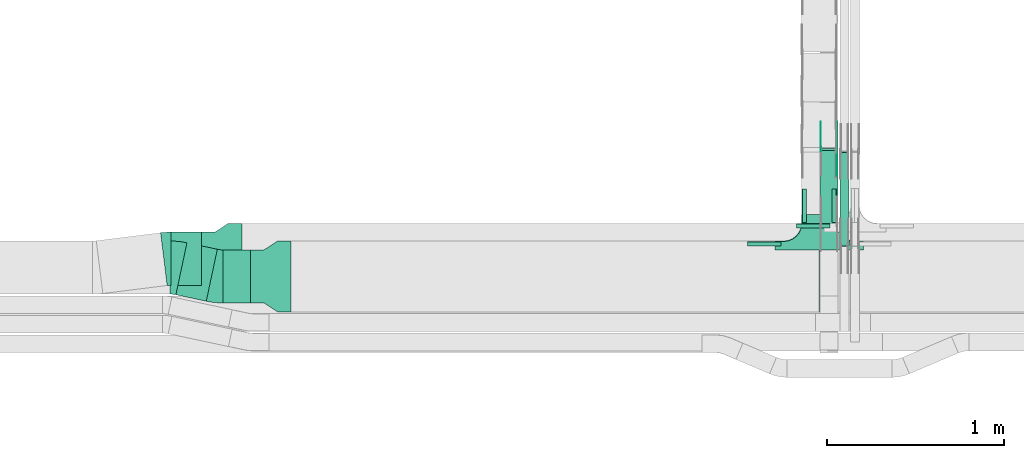
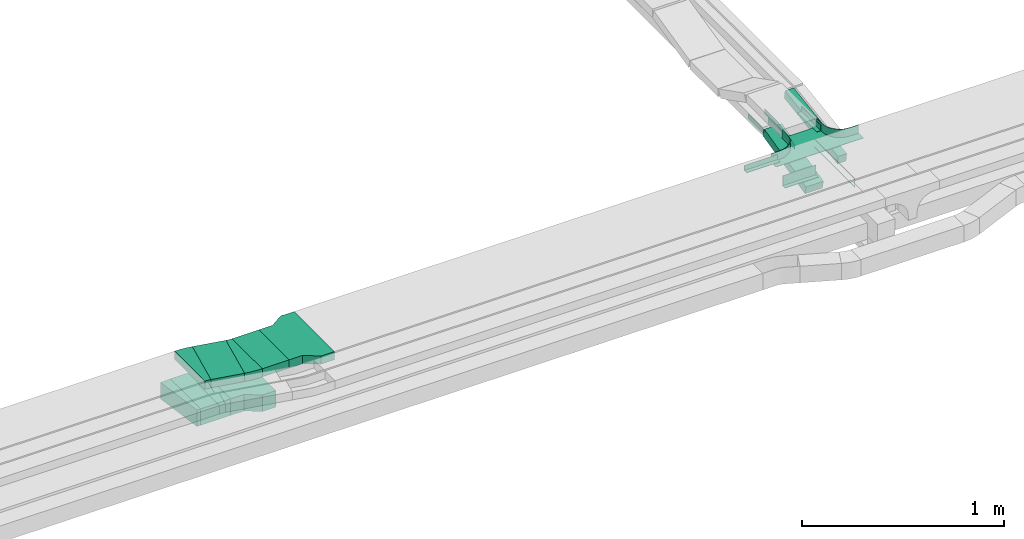
# One storey, part 17 of 28: 13 flow fittings, 5 flow segments.
"""IFC2X3 building model written with IfcOpenShell, lengths in millimetres."""

from ifc_helpers import new_model, entity, si_unit, converted_unit, derived_unit, direction, frame, frame_2d, origin, origin_2d_with_axis, place, context, subcontext, project, spatial, polyline, circle_curve, parameter, trimmed, segment, composite_curve, rectangle, outline, extrude, faceted_brep, source, transform, mapped, material, type_object, type_shapes, element, save


model = new_model("IFC2X3")

# Units and contexts
model_context = context("Model", 3, precision=0.01, world=origin(), true_north=direction((6.12303176911189e-17, 1.0)))
body_context = subcontext(model_context, "Body", "Model", "MODEL_VIEW")
ifc_project = project(units=[si_unit("LENGTHUNIT", "METRE", prefix="MILLI"), si_unit("AREAUNIT", "SQUARE_METRE"), si_unit("VOLUMEUNIT", "CUBIC_METRE"), converted_unit("PLANEANGLEUNIT", "DEGREE", entity("IfcRatioMeasure", 0.0174532925199433), si_unit("PLANEANGLEUNIT", "RADIAN"), dimensions=[0, 0, 0, 0, 0, 0, 0]), si_unit("MASSUNIT", "GRAM", prefix="KILO"), derived_unit("MASSDENSITYUNIT", [(si_unit("MASSUNIT", "GRAM", prefix="KILO"), 1), (si_unit("LENGTHUNIT", "METRE"), -3)]), derived_unit("MOMENTOFINERTIAUNIT", [(si_unit("LENGTHUNIT", "METRE"), 4)]), si_unit("TIMEUNIT", "SECOND"), si_unit("FREQUENCYUNIT", "HERTZ"), si_unit("THERMODYNAMICTEMPERATUREUNIT", "DEGREE_CELSIUS"), derived_unit("THERMALTRANSMITTANCEUNIT", [(si_unit("MASSUNIT", "GRAM", prefix="KILO"), 1), (si_unit("THERMODYNAMICTEMPERATUREUNIT", "KELVIN"), -1), (si_unit("TIMEUNIT", "SECOND"), -3)]), derived_unit("VOLUMETRICFLOWRATEUNIT", [(si_unit("LENGTHUNIT", "METRE"), 3), (si_unit("TIMEUNIT", "SECOND"), -1)]), derived_unit("MASSFLOWRATEUNIT", [(si_unit("MASSUNIT", "GRAM", prefix="KILO"), 1), (si_unit("TIMEUNIT", "SECOND"), -1)]), derived_unit("ROTATIONALFREQUENCYUNIT", [(si_unit("TIMEUNIT", "SECOND"), -1)]), si_unit("ELECTRICCURRENTUNIT", "AMPERE"), si_unit("ELECTRICVOLTAGEUNIT", "VOLT"), si_unit("POWERUNIT", "WATT"), si_unit("FORCEUNIT", "NEWTON", prefix="KILO"), si_unit("ILLUMINANCEUNIT", "LUX"), si_unit("LUMINOUSFLUXUNIT", "LUMEN"), si_unit("LUMINOUSINTENSITYUNIT", "CANDELA"), derived_unit("USERDEFINED", [(si_unit("MASSUNIT", "GRAM", prefix="KILO"), -1), (si_unit("LENGTHUNIT", "METRE"), -2), (si_unit("TIMEUNIT", "SECOND"), 3), (si_unit("LUMINOUSFLUXUNIT", "LUMEN"), 1)]), derived_unit("LINEARVELOCITYUNIT", [(si_unit("LENGTHUNIT", "METRE"), 1), (si_unit("TIMEUNIT", "SECOND"), -1)]), si_unit("PRESSUREUNIT", "PASCAL"), derived_unit("USERDEFINED", [(si_unit("LENGTHUNIT", "METRE"), -2), (si_unit("MASSUNIT", "GRAM", prefix="KILO"), 1), (si_unit("TIMEUNIT", "SECOND"), -2)]), derived_unit("LINEARFORCEUNIT", [(si_unit("MASSUNIT", "GRAM", prefix="KILO"), 1), (si_unit("LENGTHUNIT", "METRE"), 1), (si_unit("TIMEUNIT", "SECOND"), -2), (si_unit("LENGTHUNIT", "METRE"), -1)]), derived_unit("PLANARFORCEUNIT", [(si_unit("MASSUNIT", "GRAM", prefix="KILO"), 1), (si_unit("LENGTHUNIT", "METRE"), 1), (si_unit("TIMEUNIT", "SECOND"), -2), (si_unit("LENGTHUNIT", "METRE"), -2)])], contexts=[model_context])

# Site, building, storey
site_placement = place(None, frame((0.0, -0.00077364408347762, 0.0)))
site = spatial("IfcSite", under=ifc_project, at=site_placement, CompositionType="ELEMENT")
building_placement = place(site_placement, origin())
building = spatial("IfcBuilding", under=site, at=building_placement, CompositionType="ELEMENT")
storey_placement = place(building_placement, origin())
storey = spatial("IfcBuildingStorey", under=building, at=storey_placement, CompositionType="ELEMENT", Elevation=0.0)

# Flow segments
cable_carrier_segment_type = type_object("IfcCableCarrierSegmentType", PredefinedType="CABLETRAYSEGMENT")
flow_segment_1_placement = place(storey_placement, frame((43477.345822446, 8570.00006103515, 2850.0)))
element("IfcFlowSegment", 1, at=flow_segment_1_placement, inside=storey, type_object=cable_carrier_segment_type, context=body_context, shape_type="SweptSolid", body=[
    extrude(rectangle(XDim=153.839138178527, YDim=300.000000000001, at=origin_2d_with_axis()), frame((76.9195690892635, 150.0, 0.0), z_axis=(0.0, 0.0, 1.0), x_axis=(-1.0, 0.0, 0.0)), (0.0, 0.0, 1.0), 50.0000000000005),
])
flow_segment_2_placement = place(storey_placement, frame((46847.7697248974, 9014.64318097615, 2501.67316406554)))
element("IfcFlowSegment", 2, at=flow_segment_2_placement, inside=storey, type_object=cable_carrier_segment_type, context=body_context, shape_type="SweptSolid", body=[
    extrude(rectangle(XDim=50.0000000000002, YDim=426.657179477889, at=frame_2d((-5.11590769747272e-13, 1.22568621918617e-13), x_axis=(0.0, 1.0))), frame((0.0, 213.367766229282, 73.3268359354862), z_axis=(1.0, 0.0, 0.0), x_axis=(0.0, -0.973268623518936, -0.229669733472992)), (0.0, 0.0, 1.0), 99.9999999999945),
])
flow_segment_3_placement = place(storey_placement, frame((46959.820904201, 8891.69675428244, 2720.74533721461)))
element("IfcFlowSegment", 3, at=flow_segment_3_placement, inside=storey, type_object=cable_carrier_segment_type, context=body_context, shape_type="SweptSolid", body=[
    extrude(rectangle(XDim=49.9999999999999, YDim=533.151523501312, at=frame_2d((-5.11590769747272e-13, 7.99360577730113e-14), x_axis=(0.0, 1.0))), frame((0.0, 267.335697614626, 64.2546627854034), z_axis=(1.0, 0.0, 0.0), x_axis=(0.0, 0.988943608506524, 0.148292073942251)), (0.0, 0.0, 1.0), 50.000000000006),
])
flow_segment_4_placement = place(storey_placement, frame((43210.2166770361, 8580.04155239575, 2850.0)))
element("IfcFlowSegment", 4, at=flow_segment_4_placement, inside=storey, type_object=cable_carrier_segment_type, context=body_context, shape_type="SweptSolid", body=[
    extrude(rectangle(XDim=175.424176077719, YDim=299.999999999999, at=frame_2d((4.12114786740858e-12, 1.4352963262354e-12), x_axis=(1.0, 0.0))), frame((116.982122093219, 164.958508639385, 0.0), z_axis=(0.0, 0.0, 1.0), x_axis=(-0.978147600733807, 0.207911690817753, 0.0)), (0.0, 0.0, 1.0), 50.0000000000005),
])
flow_segment_5_placement = place(storey_placement, frame((43181.4742134724, 8670.17178445353, 2600.0)))
element("IfcFlowSegment", 5, at=flow_segment_5_placement, inside=storey, type_object=cable_carrier_segment_type, context=body_context, shape_type="SweptSolid", body=[
    extrude(rectangle(XDim=172.346690728659, YDim=300.000000000001, at=frame_2d((0.0, 5.40012479177676e-13), x_axis=(1.0, 0.0))), frame((86.1733453643297, 150.0, 0.0), z_axis=(0.0, 0.0, 1.0), x_axis=(-1.0, 0.0, 0.0)), (0.0, 0.0, 1.0), 100.000000000001),
])

# Flow fittings
ifc_material_1 = material(Name="G")
cable_carrier_fitting_type_1 = type_object("IfcCableCarrierFittingType", PredefinedType="NOTDEFINED", material=ifc_material_1)
shared_shape_1 = source(origin(), body_context, "Body", "SweptSolid", [
    extrude(outline(composite_curve([segment(trimmed(circle_curve(frame_2d((-44.5901162790698, 0.0), x_axis=(1.0, 0.0)), 12.5), [parameter(90.0000000000007)], [parameter(270.0)], True, "PARAMETER"), True, "CONTINUOUS"), segment(polyline([(-44.5901162790697, -12.5), (-33.0901162790698, -12.5)]), True, "CONTINUOUS"), segment(polyline([(-33.0901162790698, -12.5), (-31.2296511627907, -14.5)]), True, "CONTINUOUS"), segment(polyline([(-31.2296511627907, -14.5), (108.90988372093, -14.5)]), True, "CONTINUOUS"), segment(polyline([(108.90988372093, -14.5), (108.90988372093, 14.5)]), True, "CONTINUOUS"), segment(polyline([(108.90988372093, 14.5), (-31.2296511627907, 14.5)]), True, "CONTINUOUS"), segment(polyline([(-31.2296511627907, 14.5), (-33.0901162790698, 12.5)]), True, "CONTINUOUS"), segment(polyline([(-33.0901162790698, 12.5), (-44.5901162790699, 12.5)]), True, "CONTINUOUS")], self_intersect=False)), frame((44.5901162790698, 0.0, 0.0), z_axis=(0.0, 0.0, -1.0), x_axis=(1.0, 0.0, 0.0)), (0.0, 0.0, -1.0), 2.0),
])
type_shapes(cable_carrier_fitting_type_1, [shared_shape_1])
flow_fitting_1_placement = place(storey_placement, frame((46852.3097248873, 9439.89533631953, 2625.0), z_axis=(-1.0, 0.0, 0.0), x_axis=(0.0, 1.0, 0.0)))
element("IfcFlowFitting", 6, at=flow_fitting_1_placement, inside=storey, type_object=cable_carrier_fitting_type_1, material=ifc_material_1, context=body_context, shape_type="MappedRepresentation", body=[
    mapped(shared_shape_1, transform((0.0, 0.0, 0.0), scale=1.0)),
])
cable_carrier_fitting_type_2 = type_object("IfcCableCarrierFittingType", PredefinedType="NOTDEFINED", material=ifc_material_1)
shared_shape_2 = source(origin(), body_context, "Body", "SweptSolid", [
    extrude(outline(composite_curve([segment(trimmed(circle_curve(frame_2d((-44.5901162790697, 0.0), x_axis=(1.0, 0.0)), 12.5), [parameter(90.0000000000007)], [parameter(270.0)], True, "PARAMETER"), True, "CONTINUOUS"), segment(polyline([(-44.5901162790697, -12.5), (-33.0901162790697, -12.5)]), True, "CONTINUOUS"), segment(polyline([(-33.0901162790697, -12.5), (-31.2296511627907, -14.5)]), True, "CONTINUOUS"), segment(polyline([(-31.2296511627907, -14.5), (108.90988372093, -14.5)]), True, "CONTINUOUS"), segment(polyline([(108.90988372093, -14.5), (108.90988372093, 14.5)]), True, "CONTINUOUS"), segment(polyline([(108.90988372093, 14.5), (-31.2296511627907, 14.5)]), True, "CONTINUOUS"), segment(polyline([(-31.2296511627907, 14.5), (-33.0901162790698, 12.5)]), True, "CONTINUOUS"), segment(polyline([(-33.0901162790698, 12.5), (-44.5901162790699, 12.5)]), True, "CONTINUOUS")], self_intersect=False)), frame((44.5901162790697, 0.0, 0.0)), (0.0, 0.0, 1.0), 2.0),
])
type_shapes(cable_carrier_fitting_type_2, [shared_shape_2])
flow_fitting_2_placement = place(storey_placement, frame((46943.2297249076, 9439.89533631953, 2625.0), z_axis=(1.0, 0.0, 0.0), x_axis=(0.0, 1.0, 0.0)))
element("IfcFlowFitting", 7, at=flow_fitting_2_placement, inside=storey, type_object=cable_carrier_fitting_type_2, material=ifc_material_1, context=body_context, shape_type="MappedRepresentation", body=[
    mapped(shared_shape_2, transform((0.0, 0.0, 0.0), scale=1.0)),
])
cable_carrier_fitting_type_3 = type_object("IfcCableCarrierFittingType", PredefinedType="NOTDEFINED", material=ifc_material_1)
shared_shape_3 = source(origin(), body_context, "Body", "SweptSolid", [
    extrude(outline(composite_curve([segment(trimmed(circle_curve(frame_2d((-44.5901162790698, 0.0), x_axis=(1.0, 0.0)), 12.5), [parameter(90.0000000000007)], [parameter(270.0)], True, "PARAMETER"), True, "CONTINUOUS"), segment(polyline([(-44.5901162790697, -12.5), (-33.0901162790698, -12.5)]), True, "CONTINUOUS"), segment(polyline([(-33.0901162790698, -12.5), (-31.2296511627907, -14.5)]), True, "CONTINUOUS"), segment(polyline([(-31.2296511627907, -14.5), (108.90988372093, -14.5)]), True, "CONTINUOUS"), segment(polyline([(108.90988372093, -14.5), (108.90988372093, 14.5)]), True, "CONTINUOUS"), segment(polyline([(108.90988372093, 14.5), (-31.2296511627907, 14.5)]), True, "CONTINUOUS"), segment(polyline([(-31.2296511627907, 14.5), (-33.0901162790698, 12.5)]), True, "CONTINUOUS"), segment(polyline([(-33.0901162790698, 12.5), (-44.5901162790699, 12.5)]), True, "CONTINUOUS")], self_intersect=False)), frame((44.5901162790698, 0.0, 0.0), z_axis=(0.0, 0.0, -1.0), x_axis=(1.0, 0.0, 0.0)), (0.0, 0.0, -1.0), 2.0),
])
type_shapes(cable_carrier_fitting_type_3, [shared_shape_3])
flow_fitting_3_placement = place(storey_placement, frame((46941.2297249076, 9439.89533631955, 2625.0), z_axis=(1.0, 0.0, 0.0), x_axis=(0.0, -0.973268623517807, -0.229669733477778)))
element("IfcFlowFitting", 8, at=flow_fitting_3_placement, inside=storey, type_object=cable_carrier_fitting_type_3, material=ifc_material_1, context=body_context, shape_type="MappedRepresentation", body=[
    mapped(shared_shape_3, transform((0.0, 0.0, 0.0), scale=1.0)),
])
ifc_material_2 = material()
cable_carrier_fitting_type_4 = type_object("IfcCableCarrierFittingType", PredefinedType="NOTDEFINED", material=ifc_material_2)
shared_shape_4 = source(origin(), body_context, "Body", "SweptSolid", [
    extrude(outline(polyline([(-21.5000000000001, -9.16666666666668), (40.5, -9.16666666666668), (40.5, -6.66666666666664), (-19.0, -6.66666666666664), (-19.0, 15.8333333333333), (-21.5000000000001, 15.8333333333333), (-21.5000000000001, -9.16666666666668)])), frame((-95.0, -9.16666666666668, -26.0), z_axis=(1.0, 0.0, 0.0), x_axis=(0.0, 0.0, 1.0)), (0.0, 0.0, 1.0), 190.0),
])
type_shapes(cable_carrier_fitting_type_4, [shared_shape_4])
flow_fitting_4_placement = place(storey_placement, frame((46809.820904201, 9017.67178445353, 2650.0)))
element("IfcFlowFitting", 9, at=flow_fitting_4_placement, inside=storey, type_object=cable_carrier_fitting_type_4, material=ifc_material_2, context=body_context, shape_type="MappedRepresentation", body=[
    mapped(shared_shape_4, transform((0.0, 0.0, 0.0), scale=1.0)),
])
cable_carrier_fitting_type_5 = type_object("IfcCableCarrierFittingType", PredefinedType="NOTDEFINED", material=ifc_material_2)
shared_shape_5 = source(origin(), body_context, "Body", "Brep", [
    faceted_brep([(1.0, 197.500000000001, 25.0), (1.0, 197.500000000001, -22.5000000000011), (1.0, -200.0, -22.5000000000011), (1.0, -200.0, -25.0), (1.0, 200.0, -25.0), (1.0, 200.0, 25.0), (-1.0, 197.500000000001, 25.0), (-1.0, 200.0, 25.0), (-1.0, 200.0, -25.0), (-1.0, -200.0, -25.0), (-1.0, -200.0, -22.5000000000011), (-1.0, 197.500000000001, -22.5000000000011)], [[[0, 1, 2, 3, 4, 5]], [[6, 7, 8, 9, 10, 11]], [[1, 0, 6, 11]], [[2, 1, 11, 10]], [[3, 2, 10, 9]], [[4, 3, 9, 8]], [[5, 4, 8, 7]], [[0, 5, 7, 6]]]),
    faceted_brep([(97.4999999999995, -300.0, 25.0), (97.4999999999995, -350.0, 25.0), (100.0, -350.0, 25.0), (100.0, -300.0, 25.0), (103.407417371093, -274.118095489749, 25.0), (113.397459621556, -250.0, 25.0), (129.289321881345, -229.289321881346, 25.0), (150.0, -213.397459621557, 25.0), (174.118095489747, -203.407417371094, 25.0), (200.0, -200.0, 25.0), (250.0, -200.0, 25.0), (250.0, -197.500000000001, 25.0), (200.0, -197.500000000001, 25.0), (173.471047876991, -200.992602805371, 25.0), (148.75, -211.232396112096, 25.0), (127.521554928379, -227.521554928379, 25.0), (111.232396112095, -248.750000000001, 25.0), (100.99260280537, -273.471047876992, 25.0), (-174.118095489753, -203.407417371094, 25.0), (-150.0, -213.397459621557, 25.0), (-129.289321881351, -229.289321881346, 25.0), (-113.397459621562, -250.0, 25.0), (-103.407417371099, -274.118095489749, 25.0), (-100.0, -300.0, 25.0), (-100.0, -350.0, 25.0), (-97.5000000000056, -350.0, 25.0), (-97.5000000000057, -300.0, 25.0), (-100.992602805376, -273.471047876993, 25.0), (-111.232396112101, -248.750000000001, 25.0), (-127.521554928384, -227.52155492838, 25.0), (-148.750000000005, -211.232396112096, 25.0), (-173.471047876997, -200.992602805371, 25.0), (-200.0, -197.500000000001, 25.0), (-250.0, -197.500000000001, 25.0), (-250.0, -200.0, 25.0), (-200.0, -200.0, 25.0), (-200.0, -200.0, -25.0), (-189.212641733723, -201.420182658132, -25.0), (-174.118095489754, -203.407417371094, -25.0), (-200.0, -200.0, -27.5000000000001), (-187.059047744879, -201.703708685552, -27.5000000000001), (-174.118095489753, -203.407417371099, -27.5000000000001), (-162.059047744882, -208.402438496329, -25.0), (-150.0, -213.397459621557, -25.0), (-162.05904774488, -208.40243849633, -27.5000000000001), (-150.0, -213.397459621562, -27.5000000000001), (-139.644660940681, -221.343390751454, -25.0), (-129.289321881351, -229.289321881346, -25.0), (-139.644660940678, -221.343390751456, -27.5000000000001), (-129.28932188135, -229.289321881351, -27.5000000000001), (-113.397459621562, -250.0, -25.0), (-108.402438496332, -262.059047744874, -25.0), (-103.407417371099, -274.118095489748, -25.0), (-113.397459621561, -250.0, -27.5000000000001), (-108.40243849633, -262.059047744879, -27.5000000000001), (-103.407417371099, -274.118095489754, -27.5000000000001), (-101.703708685553, -287.059047744874, -25.0), (-100.0, -300.0, -25.0), (-101.420182658065, -289.21264173423, -27.5000000000001), (-100.0, -300.0, -27.5000000000001), (-121.343390751459, -239.644660940674, -25.0), (-121.343390751456, -239.644660940678, -27.5000000000001), (-100.0, -350.0, -27.5000000000001), (100.0, -350.0, -27.5000000000001), (97.4999999999995, -350.0, -25.0), (-97.5000000000056, -350.0, -25.0), (-97.5000000000056, -300.0, -25.0), (-100.992602805376, -273.471047876993, -25.0), (-111.2323961121, -248.750000000002, -25.0), (-127.521554928384, -227.52155492838, -25.0), (-148.750000000005, -211.232396112096, -25.0), (-173.471047876996, -200.992602805372, -25.0), (-200.0, -197.500000000001, -25.0), (100.0, -300.0, -27.5000000000001), (100.0, -300.0, -25.0), (103.407417371093, -274.11809548975, -25.0), (101.420182658216, -289.212641733042, -25.0), (101.703708685546, -287.059047744881, -27.5000000000001), (103.407417371093, -274.118095489754, -27.5000000000001), (113.397459621555, -250.0, -25.0), (108.402438496325, -262.059047744877, -25.0), (108.402438496324, -262.059047744881, -27.5000000000001), (113.397459621555, -250.0, -27.5000000000001), (121.343390751452, -239.644660940677, -25.0), (129.289321881344, -229.289321881347, -25.0), (121.34339075145, -239.644660940679, -27.5000000000001), (129.289321881345, -229.289321881352, -27.5000000000001), (150.0, -213.397459621557, -25.0), (139.644660940673, -221.343390751456, -25.0), (139.644660940671, -221.343390751457, -27.5000000000001), (150.0, -213.397459621562, -27.5000000000001), (174.118095489747, -203.407417371094, -25.0), (162.059047744874, -208.40243849633, -25.0), (162.059047744873, -208.402438496331, -27.5000000000001), (174.118095489747, -203.407417371099, -27.5000000000001), (187.059047744873, -201.703708685553, -25.0), (200.0, -200.0, -25.0), (189.212641734218, -201.420182658066, -27.5000000000001), (200.0, -200.0, -27.5000000000001), (200.0, -197.500000000001, -25.0), (173.471047876991, -200.992602805371, -25.0), (148.749999999999, -211.232396112096, -25.0), (127.521554928378, -227.52155492838, -25.0), (111.232396112094, -248.750000000001, -25.0), (100.99260280537, -273.471047876993, -25.0), (97.4999999999995, -300.0, -25.0), (-250.0, -197.500000000001, -25.0), (250.0, -197.500000000001, -25.0), (-250.0, -150.0, -25.0), (-250.0, -150.0, -27.5000000000001), (-250.0, -200.0, -27.5000000000001), (250.0, -200.0, -27.5000000000001), (250.0, -150.0, -27.5000000000001), (250.0, -150.0, -25.0)], [[[0, 1, 2, 3, 4, 5, 6, 7, 8, 9, 10, 11, 12, 13, 14, 15, 16, 17]], [[18, 19, 20, 21, 22, 23, 24, 25, 26, 27, 28, 29, 30, 31, 32, 33, 34, 35]], [[18, 35, 36]], [[18, 36, 37]], [[18, 37, 38]], [[37, 36, 39]], [[37, 39, 40]], [[38, 40, 41]], [[37, 40, 38]], [[19, 18, 38]], [[19, 38, 42]], [[19, 42, 43]], [[38, 41, 42]], [[44, 42, 41]], [[42, 44, 43]], [[44, 45, 43]], [[20, 43, 46]], [[19, 43, 20]], [[20, 46, 47]], [[46, 43, 45]], [[46, 45, 48]], [[48, 49, 47]], [[46, 48, 47]], [[22, 21, 50]], [[22, 50, 51]], [[22, 51, 52]], [[50, 53, 51]], [[54, 51, 53]], [[51, 54, 52]], [[54, 55, 52]], [[23, 22, 52]], [[23, 52, 56]], [[23, 56, 57]], [[52, 55, 56]], [[58, 56, 55]], [[58, 59, 57]], [[56, 58, 57]], [[21, 47, 60]], [[20, 47, 21]], [[21, 60, 50]], [[60, 47, 49]], [[60, 49, 61]], [[60, 61, 50]], [[61, 53, 50]], [[24, 23, 57, 59, 62]], [[25, 24, 62, 63, 2, 1, 64, 65]], [[26, 25, 65, 66]], [[27, 26, 66, 67]], [[28, 27, 67, 68]], [[29, 28, 68, 69]], [[30, 29, 69, 70]], [[31, 30, 70, 71]], [[32, 31, 71, 72]], [[3, 2, 63, 73, 74]], [[4, 3, 75]], [[3, 76, 75]], [[3, 74, 76]], [[76, 74, 73]], [[76, 73, 77]], [[75, 77, 78]], [[76, 77, 75]], [[5, 4, 79]], [[4, 80, 79]], [[4, 75, 80]], [[75, 78, 80]], [[81, 80, 78]], [[80, 81, 79]], [[81, 82, 79]], [[5, 79, 83]], [[5, 83, 84]], [[84, 6, 5]], [[83, 79, 82]], [[83, 82, 85]], [[85, 86, 84]], [[83, 85, 84]], [[7, 6, 87]], [[6, 88, 87]], [[6, 84, 88]], [[88, 84, 86]], [[88, 86, 89]], [[88, 89, 87]], [[89, 90, 87]], [[8, 7, 91]], [[7, 92, 91]], [[7, 87, 92]], [[87, 90, 92]], [[93, 92, 90]], [[92, 93, 91]], [[93, 94, 91]], [[8, 91, 95]], [[8, 95, 96]], [[8, 96, 9]], [[91, 94, 95]], [[97, 95, 94]], [[97, 98, 96]], [[95, 97, 96]], [[13, 12, 99, 100]], [[14, 13, 100, 101]], [[15, 14, 101, 102]], [[102, 103, 16, 15]], [[17, 16, 103, 104]], [[104, 105, 0, 17]], [[1, 0, 105, 64]], [[33, 32, 72, 106]], [[12, 11, 107, 99]], [[34, 33, 106, 108, 109, 110]], [[35, 34, 110, 39, 36]], [[10, 9, 96, 98, 111]], [[10, 111, 112, 113, 107, 11]], [[107, 113, 108, 106, 72, 71, 70, 69, 68, 67, 66, 65, 64, 105, 104, 103, 102, 101, 100, 99]], [[110, 109, 112, 111, 98, 97, 94, 93, 90, 89, 86, 85, 82, 81, 78, 77, 73, 63, 62, 59, 58, 55, 54, 53, 61, 49, 48, 45, 44, 41, 40, 39]], [[108, 113, 112, 109]]]),
])
type_shapes(cable_carrier_fitting_type_5, [shared_shape_5])
flow_fitting_5_placement = place(storey_placement, frame((46842.1849606245, 8720.00006103515, 2875.0), z_axis=(0.0, 0.0, 1.0), x_axis=(-1.0, 0.0, 0.0)))
element("IfcFlowFitting", 10, at=flow_fitting_5_placement, inside=storey, type_object=cable_carrier_fitting_type_5, material=ifc_material_2, context=body_context, shape_type="MappedRepresentation", body=[
    mapped(shared_shape_5, transform((0.0, 0.0, 0.0), scale=1.0)),
])
cable_carrier_fitting_type_6 = type_object("IfcCableCarrierFittingType", PredefinedType="NOTDEFINED", material=ifc_material_2)
shared_shape_6 = source(origin(), body_context, "Body", "SweptSolid", [
    extrude(outline(polyline([(-9.16666666666668, -11.5000000000001), (15.8333333333333, -11.5000000000001), (15.8333333333333, -9.0), (-6.66666666666664, -9.0), (-6.66666666666664, 20.5), (-9.16666666666668, 20.5), (-9.16666666666668, -11.5000000000001)])), frame((-95.0, 9.16666666666668, -11.0), z_axis=(1.0, 0.0, 0.0), x_axis=(0.0, 1.0, 0.0)), (0.0, 0.0, 1.0), 190.0),
])
type_shapes(cable_carrier_fitting_type_6, [shared_shape_6])
for number, where, z_axis, x_axis in (
    (11, (46744.6849606245, 9120.00006103515, 2875.0), (0.0, 0.0, 1.0), (0.0, -1.0, 0.0)),
    (12, (46939.6849606245, 9120.00006103515, 2875.0), (0.0, 0.0, 1.0), (0.0, 1.0, 0.0)),
):
    element("IfcFlowFitting", number, at=place(storey_placement, frame(where, z_axis=z_axis, x_axis=x_axis)), inside=storey, type_object=cable_carrier_fitting_type_6, material=ifc_material_2, context=body_context, shape_type="MappedRepresentation", body=[
        mapped(shared_shape_6, transform((0.0, 0.0, 0.0), scale=1.0)),
    ])
cable_carrier_fitting_type_7 = type_object("IfcCableCarrierFittingType", PredefinedType="NOTDEFINED", material=ifc_material_2)
shared_shape_7 = source(origin(), body_context, "Body", "SweptSolid", [
    extrude(outline(polyline([(-11.5000000000001, -9.16666666666668), (20.5, -9.16666666666668), (20.5, -6.66666666666664), (-9.0, -6.66666666666664), (-9.0, 15.8333333333333), (-11.5000000000001, 15.8333333333333), (-11.5000000000001, -9.16666666666668)])), frame((-95.0, -9.16666666666668, -11.0), z_axis=(1.0, 0.0, 0.0), x_axis=(0.0, 0.0, 1.0)), (0.0, 0.0, 1.0), 190.0),
])
type_shapes(cable_carrier_fitting_type_7, [shared_shape_7])
flow_fitting_6_placement = place(storey_placement, frame((46532.1849606245, 8917.50006103515, 2875.0)))
element("IfcFlowFitting", 13, at=flow_fitting_6_placement, inside=storey, type_object=cable_carrier_fitting_type_7, material=ifc_material_2, context=body_context, shape_type="MappedRepresentation", body=[
    mapped(shared_shape_7, transform((0.0, 0.0, 0.0), scale=1.0)),
])
ifc_material_3 = material()
cable_carrier_fitting_type_8 = type_object("IfcCableCarrierFittingType", PredefinedType="NOTDEFINED", material=ifc_material_3)
shared_shape_8 = source(origin(), body_context, "Body", "SweptSolid", [
    extrude(outline(polyline([(-115.0, -200.0), (-38.3333333333285, -200.0), (38.3333333333253, -150.0), (115.0, -150.0), (115.0, 150.0), (38.3333333333381, 150.0), (-38.3333333333285, 200.0), (-115.0, 200.0), (-115.0, -200.0)])), frame((115.0, 0.0, -25.0)), (0.0, 0.0, 1.0), 50.0000000000003),
])
type_shapes(cable_carrier_fitting_type_8, [shared_shape_8])
flow_fitting_7_placement = place(storey_placement, frame((43861.1849606245, 8720.00006103513, 2875.0), z_axis=(0.0, 0.0, 1.0), x_axis=(-1.0, 0.0, 0.0)))
element("IfcFlowFitting", 14, at=flow_fitting_7_placement, inside=storey, type_object=cable_carrier_fitting_type_8, material=ifc_material_3, Name="470_DKC_S5_adapter", context=body_context, shape_type="MappedRepresentation", body=[
    mapped(shared_shape_8, transform((0.0, 0.0, 0.0), scale=1.0)),
])
cable_carrier_fitting_type_9 = type_object("IfcCableCarrierFittingType", Name="470_DKC_S5_Variable Angle Elbow 0-45:-", PredefinedType="NOTDEFINED", material=ifc_material_3)
shared_shape_9 = source(origin(), body_context, "Body", "SweptSolid", [
    extrude(outline(composite_curve([segment(polyline([(-32.1812905228461, -153.329837812634), (-31.1812905228447, -153.329837812634)]), True, "CONTINUOUS"), segment(trimmed(circle_curve(frame_2d((-31.1812905228529, 296.670162187366), x_axis=(0.0, -1.0)), 450.0), [parameter(0.0)], [parameter(12.0000000000001)], True, "PARAMETER"), True, "CONTINUOUS"), segment(polyline([(62.3789703451476, -143.496258142845), (63.3571179458808, -143.288346452027)]), True, "CONTINUOUS"), segment(polyline([(63.3571179458808, -143.288346452027), (0.983610700548323, 150.155933768114)]), True, "CONTINUOUS"), segment(polyline([(0.983610700548349, 150.155933768113), (0.00546309981392656, 149.948022077296)]), True, "CONTINUOUS"), segment(trimmed(circle_curve(frame_2d((-31.1812905228529, 296.670162187366), x_axis=(0.0, -1.0)), 150.0), [parameter(0.0)], [parameter(12.0000000000001)], True, "PARAMETER"), False, "CONTINUOUS"), segment(polyline([(-31.1812905228498, 146.670162187366), (-32.1812905228512, 146.670162187366)]), True, "CONTINUOUS"), segment(polyline([(-32.1812905228512, 146.670162187366), (-32.1812905228461, -153.329837812634)]), True, "CONTINUOUS")], self_intersect=False)), frame((-0.3499800568457, 3.32983781262558, -25.0)), (0.0, 0.0, 1.0), 49.9999999999997),
])
type_shapes(cable_carrier_fitting_type_9, [shared_shape_9])
for number, where, z_axis, x_axis, name in (
    (15, (43444.8145518662, 8720.00006103517, 2875.0), (0.0, 0.0, 1.0), (0.978147600733805, -0.207911690817761, 0.0), "470_DKC_S5_Variable Angle Elbow 0-45:-"),
    (16, (43209.5830463924, 8770.00006103511, 2875.0), (0.0, 0.0, 1.0), (-0.978147600733808, 0.207911690817749, 0.0), "470_DKC_S5_Variable Angle Elbow 0-45:-"),
):
    element("IfcFlowFitting", number, at=place(storey_placement, frame(where, z_axis=z_axis, x_axis=x_axis)), inside=storey, type_object=cable_carrier_fitting_type_9, material=ifc_material_3, Name=name, ObjectType="470_DKC_S5_Variable Angle Elbow 0-45:-", context=body_context, shape_type="MappedRepresentation", body=[
        mapped(shared_shape_9, transform((0.0, 0.0, 0.0), scale=1.0)),
    ])
cable_carrier_fitting_type_10 = type_object("IfcCableCarrierFittingType", PredefinedType="NOTDEFINED", material=ifc_material_3)
shared_shape_10 = source(origin(), body_context, "Body", "SweptSolid", [
    extrude(outline(polyline([(-115.0, -200.0), (-38.3333333333284, -200.0), (38.3333333333252, -150.0), (115.0, -150.0), (115.0, 150.0), (38.3333333333382, 150.0), (-38.3333333333284, 200.0), (-115.0, 200.0), (-115.0, -200.0)])), frame((115.0, 0.0, -50.0)), (0.0, 0.0, 1.0), 100.0),
])
type_shapes(cable_carrier_fitting_type_10, [shared_shape_10])
flow_fitting_8_placement = place(storey_placement, frame((43583.820904201, 8820.17178445352, 2650.0), z_axis=(0.0, 0.0, 1.0), x_axis=(-1.0, 0.0, 0.0)))
element("IfcFlowFitting", 17, at=flow_fitting_8_placement, inside=storey, type_object=cable_carrier_fitting_type_10, material=ifc_material_3, Name="470_DKC_S5_adapter", context=body_context, shape_type="MappedRepresentation", body=[
    mapped(shared_shape_10, transform((0.0, 0.0, 0.0), scale=1.0)),
])
cable_carrier_fitting_type_11 = type_object("IfcCableCarrierFittingType", Name="470_DKC_S5_Variable Angle Elbow 0-45:-", PredefinedType="NOTDEFINED", material=ifc_material_3)
shared_shape_11 = source(origin(), body_context, "Body", "SweptSolid", [
    extrude(outline(composite_curve([segment(polyline([(-19.5760009358106, -151.185873692164), (-18.576000935809, -151.185873692164)]), True, "CONTINUOUS"), segment(trimmed(circle_curve(frame_2d((-18.5760009358173, 298.814126307836), x_axis=(0.0, -1.0)), 450.0), [parameter(0.0)], [parameter(7.11451349008865)], True, "PARAMETER"), True, "CONTINUOUS"), segment(polyline([(37.1577764240392, -147.721142244606), (38.1500770208219, -147.597289406029)]), True, "CONTINUOUS"), segment(polyline([(38.1500770208219, -147.597289406029), (0.994225447585218, 150.092889628933)]), True, "CONTINUOUS"), segment(polyline([(0.994225447585212, 150.092889628933), (0.00192485080150853, 149.969036790356)]), True, "CONTINUOUS"), segment(trimmed(circle_curve(frame_2d((-18.5760009358173, 298.814126307836), x_axis=(0.0, -1.0)), 150.0), [parameter(0.0)], [parameter(7.11451349008865)], True, "PARAMETER"), False, "CONTINUOUS"), segment(polyline([(-18.5760009358141, 148.814126307836), (-19.5760009358156, 148.814126307836)]), True, "CONTINUOUS"), segment(polyline([(-19.5760009358156, 148.814126307836), (-19.5760009358106, -151.185873692164)]), True, "CONTINUOUS")], self_intersect=False)), frame((-0.0737207142265264, 1.18587369215512, -50.0)), (0.0, 0.0, 1.0), 99.9999999999998),
])
type_shapes(cable_carrier_fitting_type_11, [shared_shape_11])
flow_fitting_9_placement = place(storey_placement, frame((43161.8244918223, 8820.17178445353, 2650.0), z_axis=(0.0, 0.0, 1.0), x_axis=(-1.0, 0.0, 0.0)))
element("IfcFlowFitting", 18, at=flow_fitting_9_placement, inside=storey, type_object=cable_carrier_fitting_type_11, material=ifc_material_3, Name="470_DKC_S5_Variable Angle Elbow 0-45:-", ObjectType="470_DKC_S5_Variable Angle Elbow 0-45:-", context=body_context, shape_type="MappedRepresentation", body=[
    mapped(shared_shape_11, transform((0.0, 0.0, 0.0), scale=1.0)),
])

save(model, "model.ifc")
